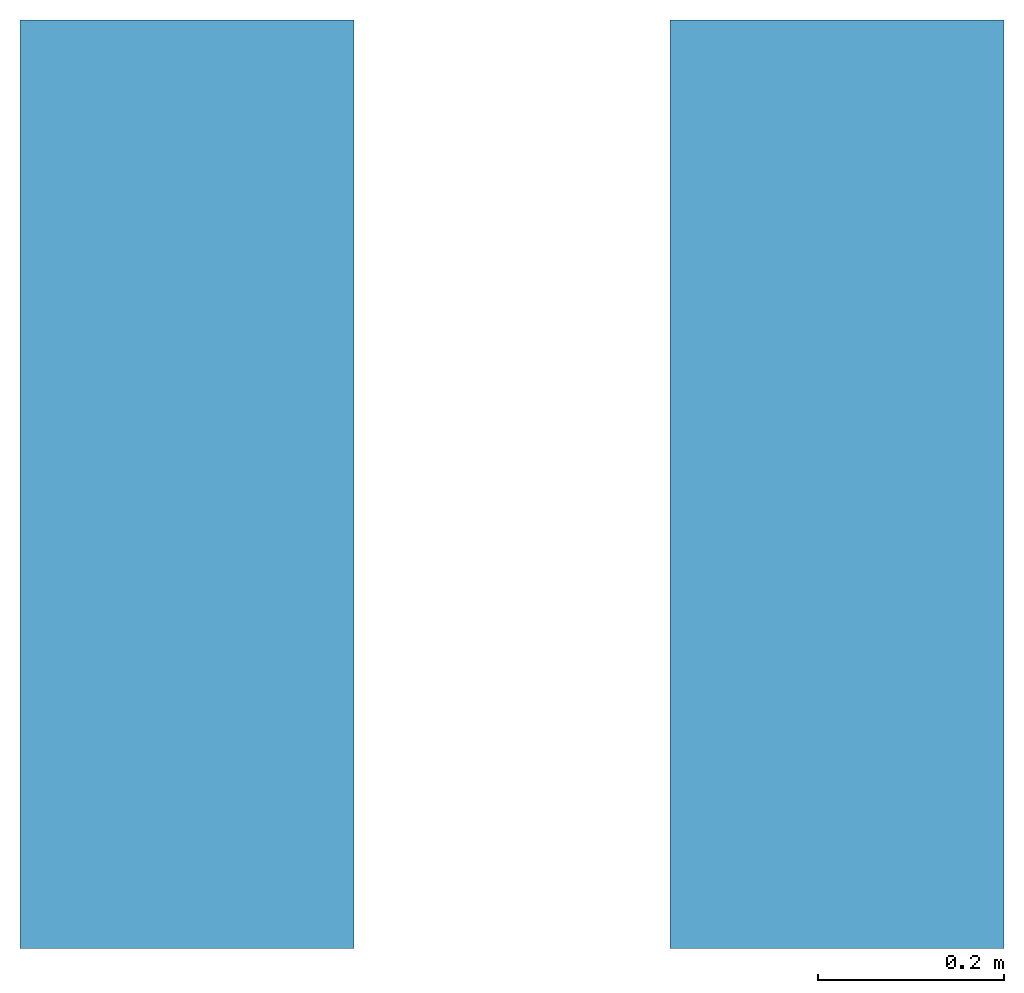
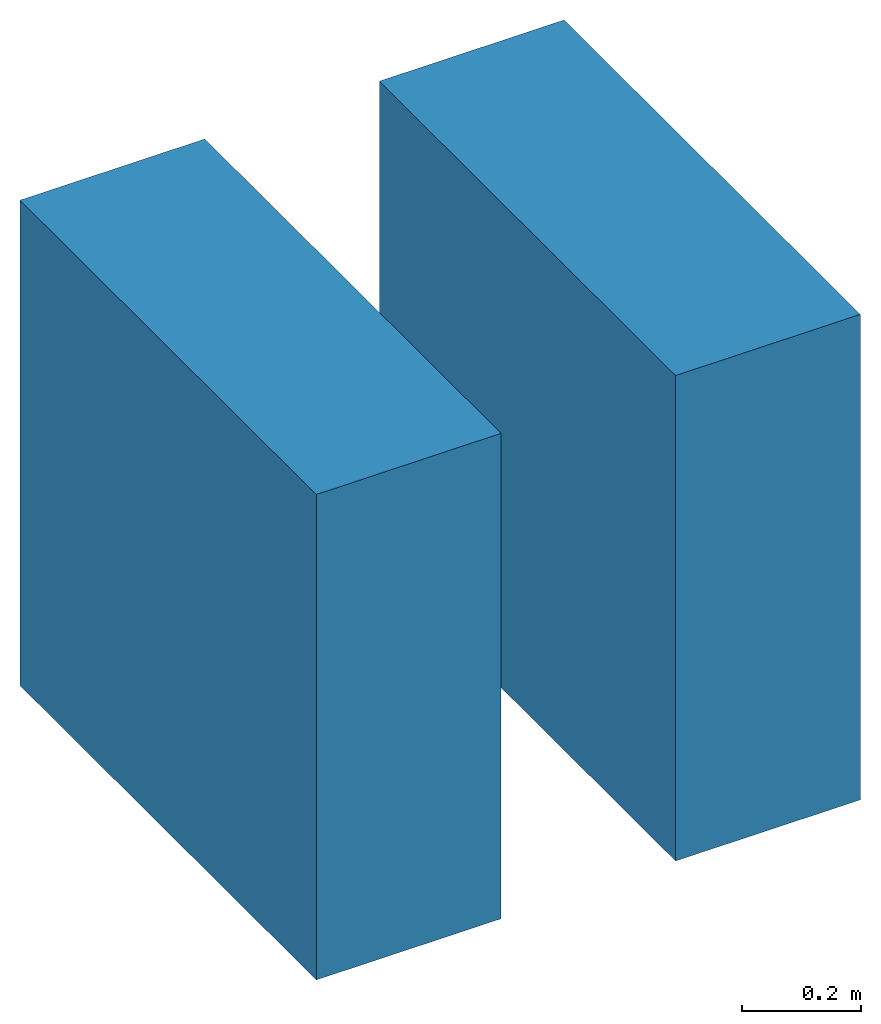
# One storey: 2 walls.
"""IFC2X3 building model written with IfcOpenShell, lengths in millimetres."""

from ifc_helpers import new_model, entity, si_unit, converted_unit, derived_unit, direction, frame, frame_2d, origin, place, context, subcontext, project, spatial, rectangle, extrude, material, layer, layer_set, layer_usage, type_object, element, save


model = new_model("IFC2X3")

# Units and contexts
model_context = context("Model", 3, precision=0.01, world=origin(), true_north=direction((6.12303176911189e-17, 1.0)))
context_of_model = context(None, 3, precision=0.01, world=origin(), true_north=direction((6.12303176911189e-17, 1.0)))
body_context = subcontext(model_context, "Body", "Model", "MODEL_VIEW")
ifc_project = project(units=[si_unit("LENGTHUNIT", "METRE", prefix="MILLI"), si_unit("AREAUNIT", "SQUARE_METRE"), si_unit("VOLUMEUNIT", "CUBIC_METRE"), converted_unit("PLANEANGLEUNIT", "DEGREE", entity("IfcRatioMeasure", 0.0174532925199433), si_unit("PLANEANGLEUNIT", "RADIAN"), dimensions=[0, 0, 0, 0, 0, 0, 0]), si_unit("MASSUNIT", "GRAM", prefix="KILO"), si_unit("TIMEUNIT", "SECOND"), si_unit("FREQUENCYUNIT", "HERTZ"), si_unit("THERMODYNAMICTEMPERATUREUNIT", "DEGREE_CELSIUS"), derived_unit("THERMALTRANSMITTANCEUNIT", [(si_unit("MASSUNIT", "GRAM", prefix="KILO"), 1), (si_unit("THERMODYNAMICTEMPERATUREUNIT", "KELVIN"), -1), (si_unit("TIMEUNIT", "SECOND"), -3)]), derived_unit("VOLUMETRICFLOWRATEUNIT", [(si_unit("LENGTHUNIT", "METRE"), 3), (si_unit("TIMEUNIT", "SECOND"), -1)]), si_unit("ELECTRICCURRENTUNIT", "AMPERE"), si_unit("ELECTRICVOLTAGEUNIT", "VOLT"), si_unit("POWERUNIT", "WATT"), si_unit("FORCEUNIT", "NEWTON", prefix="KILO"), si_unit("ILLUMINANCEUNIT", "LUX"), si_unit("LUMINOUSFLUXUNIT", "LUMEN"), si_unit("LUMINOUSINTENSITYUNIT", "CANDELA"), si_unit("PRESSUREUNIT", "PASCAL")], contexts=[model_context, context_of_model])

# Site, building, storey
site_placement = place(None, origin())
site = spatial("IfcSite", under=ifc_project, at=site_placement, CompositionType="ELEMENT")
building_placement = place(site_placement, origin())
building = spatial("IfcBuilding", under=site, at=building_placement, CompositionType="ELEMENT")
storey_placement = place(building_placement, origin())
storey = spatial("IfcBuildingStorey", under=building, at=storey_placement, CompositionType="ELEMENT", Elevation=0.0)

# Walls
ifc_material_1 = material()
ifc_layer_1 = layer(ifc_material_1, 10.0)
ifc_material_2 = material()
ifc_layer_2 = layer(ifc_material_2, 1.0)
ifc_material_3 = material()
ifc_layer_3 = layer(ifc_material_3, 10.0)
ifc_material_4 = material()
ifc_layer_4 = layer(ifc_material_4, 100.0)
ifc_material_5 = material()
ifc_layer_5 = layer(ifc_material_5, 9.0)
ifc_material_6 = material()
ifc_layer_6 = layer(ifc_material_6, 10.0)
ifc_material_7 = material()
ifc_layer_7 = layer(ifc_material_7, 200.0)
ifc_material_8 = material()
ifc_layer_8 = layer(ifc_material_8, 20.0)
ifc_layer_set_1 = layer_set([ifc_layer_1, ifc_layer_2, ifc_layer_3, ifc_layer_4, ifc_layer_5, ifc_layer_6, ifc_layer_7, ifc_layer_8])
ifc_layer_usage_1 = layer_usage(ifc_layer_set_1, "AXIS2", "POSITIVE", -180.0)
wall_type_1 = type_object("IfcWallType", PredefinedType="STANDARD", material=ifc_layer_set_1)
wall_1_placement = place(storey_placement, frame((3431.90671950462, 3044.93365683083, 0.0), z_axis=(0.0, 0.0, 1.0), x_axis=(0.0, -1.0, 0.0)))
element("IfcWallStandardCase", 1, at=wall_1_placement, inside=storey, type_object=wall_type_1, material=ifc_layer_usage_1, context=body_context, shape_type="SweptSolid", body=[
    extrude(rectangle(XDim=1000.0, YDim=360.0, at=frame_2d((500.0, 0.0), x_axis=(-1.0, 0.0))), origin(), (0.0, 0.0, 1.0), 1000.0),
])
ifc_layer_9 = layer(ifc_material_1, 10.0)
ifc_layer_10 = layer(ifc_material_2, 1.0)
ifc_layer_11 = layer(ifc_material_3, 10.0)
ifc_material_9 = material()
ifc_layer_12 = layer(ifc_material_9, 100.0)
ifc_layer_13 = layer(ifc_material_5, 9.0)
ifc_layer_14 = layer(ifc_material_6, 10.0)
ifc_layer_15 = layer(ifc_material_7, 200.0)
ifc_layer_16 = layer(ifc_material_8, 20.0)
ifc_layer_set_2 = layer_set([ifc_layer_9, ifc_layer_10, ifc_layer_11, ifc_layer_12, ifc_layer_13, ifc_layer_14, ifc_layer_15, ifc_layer_16])
ifc_layer_usage_2 = layer_usage(ifc_layer_set_2, "AXIS2", "POSITIVE", -180.0)
wall_type_2 = type_object("IfcWallType", PredefinedType="STANDARD", material=ifc_layer_set_2)
wall_2_placement = place(storey_placement, frame((4131.90671950462, 3044.93365683083, 0.0), z_axis=(0.0, 0.0, 1.0), x_axis=(0.0, -1.0, 0.0)))
element("IfcWallStandardCase", 2, at=wall_2_placement, inside=storey, type_object=wall_type_2, material=ifc_layer_usage_2, context=body_context, shape_type="SweptSolid", body=[
    extrude(rectangle(XDim=1000.0, YDim=360.0, at=frame_2d((500.0, 0.0), x_axis=(-1.0, 0.0))), origin(), (0.0, 0.0, 1.0), 1000.0),
])

save(model, "model.ifc")
